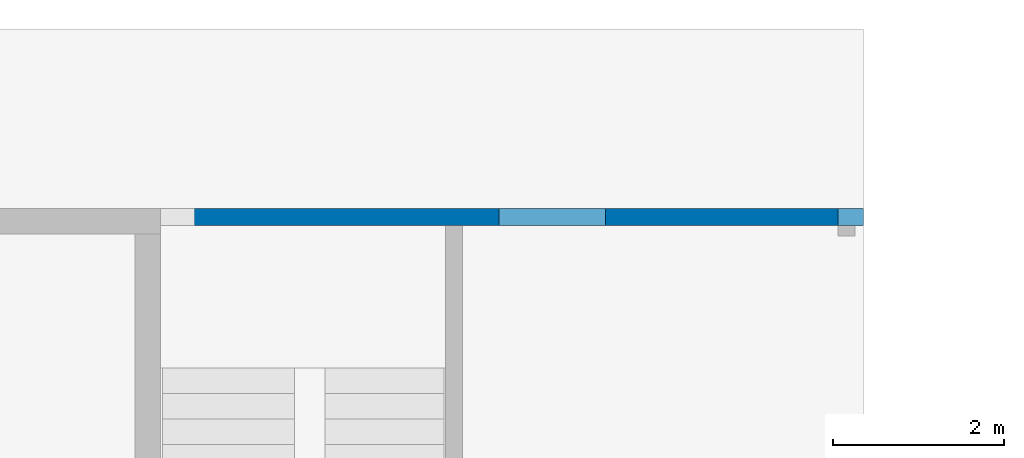
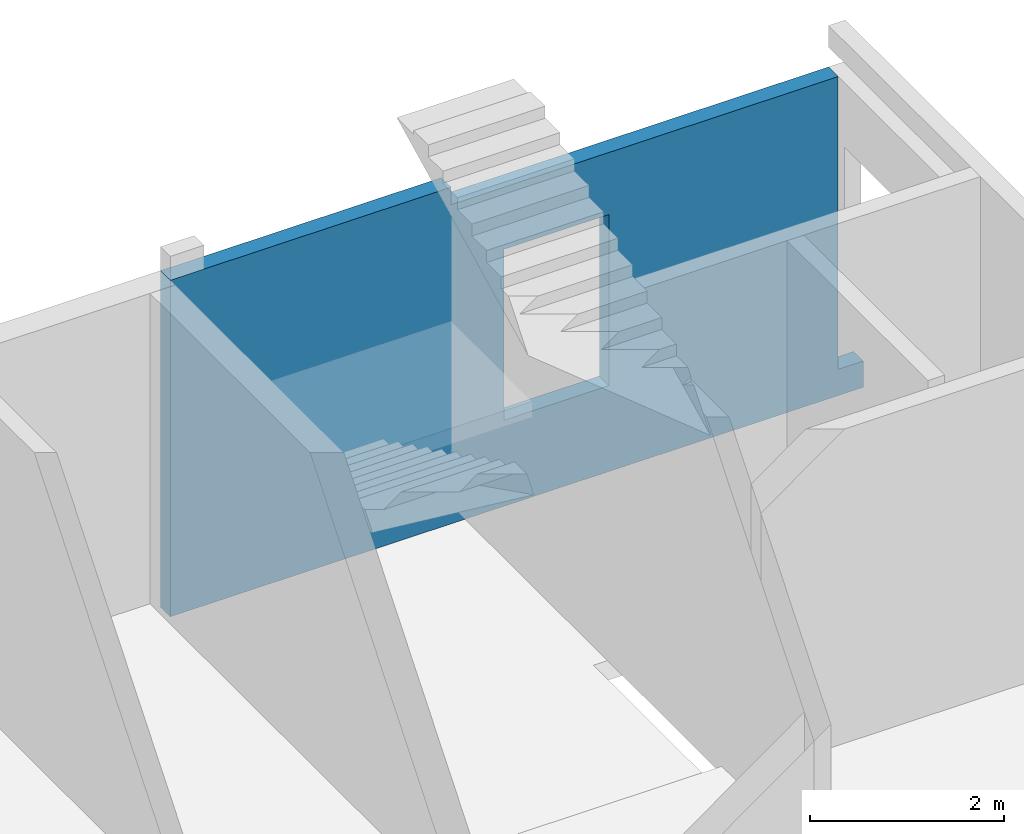
# One storey, part 8 of 8: 1 wall, 13 openings.
"""IFC4 building model written with IfcOpenShell, lengths in millimetres."""

from ifc_helpers import new_model, entity, si_unit, converted_unit, derived_unit, direction, frame, origin, place, context, subcontext, project, spatial, indexed_curve, outline, extrude, polygons, material, type_object, element, save


model = new_model("IFC4")

# Units and contexts
model_context = context("Model", 3, precision=0.01, world=origin(), true_north=direction((6.12303176911189e-17, 1.0)))
plan_context = context("Plan", 3, precision=0.01, world=origin(), true_north=direction((6.12303176911189e-17, 1.0)))
body_context = subcontext(model_context, "Body", "Model", "MODEL_VIEW")
ifc_project = project(units=[si_unit("LENGTHUNIT", "METRE", prefix="MILLI"), si_unit("AREAUNIT", "SQUARE_METRE"), si_unit("VOLUMEUNIT", "CUBIC_METRE"), converted_unit("PLANEANGLEUNIT", "DEGREE", entity("IfcRatioMeasure", 0.0174532925199433), si_unit("PLANEANGLEUNIT", "RADIAN"), dimensions=[0, 0, 0, 0, 0, 0, 0]), si_unit("MASSUNIT", "GRAM", prefix="KILO"), derived_unit("MASSDENSITYUNIT", [(si_unit("MASSUNIT", "GRAM", prefix="KILO"), 1), (si_unit("LENGTHUNIT", "METRE"), -3)]), derived_unit("MOMENTOFINERTIAUNIT", [(si_unit("LENGTHUNIT", "METRE"), 4)]), si_unit("TIMEUNIT", "SECOND"), si_unit("FREQUENCYUNIT", "HERTZ"), si_unit("THERMODYNAMICTEMPERATUREUNIT", "DEGREE_CELSIUS"), derived_unit("THERMALTRANSMITTANCEUNIT", [(si_unit("MASSUNIT", "GRAM", prefix="KILO"), 1), (si_unit("THERMODYNAMICTEMPERATUREUNIT", "KELVIN"), -1), (si_unit("TIMEUNIT", "SECOND"), -3)]), derived_unit("VOLUMETRICFLOWRATEUNIT", [(si_unit("LENGTHUNIT", "METRE"), 3), (si_unit("TIMEUNIT", "SECOND"), -1)]), derived_unit("MASSFLOWRATEUNIT", [(si_unit("MASSUNIT", "GRAM", prefix="KILO"), 1), (si_unit("TIMEUNIT", "SECOND"), -1)]), derived_unit("ROTATIONALFREQUENCYUNIT", [(si_unit("TIMEUNIT", "SECOND"), -1)]), si_unit("ELECTRICCURRENTUNIT", "AMPERE"), si_unit("ELECTRICVOLTAGEUNIT", "VOLT"), si_unit("POWERUNIT", "WATT"), si_unit("FORCEUNIT", "NEWTON", prefix="KILO"), si_unit("ILLUMINANCEUNIT", "LUX"), si_unit("LUMINOUSFLUXUNIT", "LUMEN"), si_unit("LUMINOUSINTENSITYUNIT", "CANDELA"), derived_unit("USERDEFINED", [(si_unit("MASSUNIT", "GRAM", prefix="KILO"), -1), (si_unit("LENGTHUNIT", "METRE"), -2), (si_unit("TIMEUNIT", "SECOND"), 3), (si_unit("LUMINOUSFLUXUNIT", "LUMEN"), 1)]), derived_unit("LINEARVELOCITYUNIT", [(si_unit("LENGTHUNIT", "METRE"), 1), (si_unit("TIMEUNIT", "SECOND"), -1)]), si_unit("PRESSUREUNIT", "PASCAL"), derived_unit("USERDEFINED", [(si_unit("LENGTHUNIT", "METRE"), -2), (si_unit("MASSUNIT", "GRAM", prefix="KILO"), 1), (si_unit("TIMEUNIT", "SECOND"), -2)]), derived_unit("LINEARFORCEUNIT", [(si_unit("MASSUNIT", "GRAM", prefix="KILO"), 1), (si_unit("LENGTHUNIT", "METRE"), 1), (si_unit("TIMEUNIT", "SECOND"), -2), (si_unit("LENGTHUNIT", "METRE"), -1)]), derived_unit("PLANARFORCEUNIT", [(si_unit("MASSUNIT", "GRAM", prefix="KILO"), 1), (si_unit("LENGTHUNIT", "METRE"), 1), (si_unit("TIMEUNIT", "SECOND"), -2), (si_unit("LENGTHUNIT", "METRE"), -2)])], contexts=[model_context, plan_context])

# Site, building, storey
site_placement = place(None, origin())
site = spatial("IfcSite", under=ifc_project, at=site_placement, CompositionType="ELEMENT")
building_placement = place(site_placement, origin())
building = spatial("IfcBuilding", under=site, at=building_placement, CompositionType="ELEMENT")
storey_placement = place(building_placement, origin())
storey = spatial("IfcBuildingStorey", under=building, at=storey_placement, CompositionType="ELEMENT", Elevation=0.0)

# Wall, openings
ifc_material = material()
wall_type = type_object("IfcWallType", PredefinedType="STANDARD")
wall_placement = place(storey_placement, frame((73670.0002685547, 20399.999226356, -480.0), z_axis=(0.0, 0.0, 1.0), x_axis=(-1.0, 0.0, 0.0)))
wall = element("IfcWall", 1, at=wall_placement, inside=storey, type_object=wall_type, material=ifc_material, PredefinedType="NOTDEFINED", context=body_context, shape_type="Tessellation", body=[
    polygons([(-4.19026652712969e-13, -99.9999999999989, 2.70716782324598e-13), (8240.00000000001, -99.9999999999989, 2.70716782324598e-13), (8240.00000000001, -99.9999999999989, 330.0), (8240.00000000001, -99.9999999999989, 4230.0), (7839.99999999997, -99.9999999999989, 4230.0), (4900.0, -99.9999999999946, 4230.0), (4900.0, -99.9999999999946, 4010.0), (300.000000000009, -99.9999999999989, 4010.0), (300.000000000009, -99.9999999999989, 330.0), (100.000000000012, -99.9999999999989, 330.0), (-4.19026652712969e-13, -99.9999999999989, 330.0), (3025.00000000001, -99.9999999999989, 3229.99999999804), (4275.00000000001, -99.9999999999989, 3229.99999999804), (4275.00000000001, -99.9999999999989, 1080.0), (3025.00000000001, -99.9999999999989, 1080.0), (8240.00000000001, 99.9999999999989, 2.70716782324598e-13), (300.0, 99.9999999999989, 2.70716782324598e-13), (-1.09107028414708e-12, 99.9999999999989, 2.70716782324598e-13), (-1.09107028414708e-12, 99.9999999999989, 330.0), (300.000000000009, 99.9999999999989, 330.0), (300.000000000009, 99.9999999999989, 4010.0), (4900.0, 100.000000000003, 4010.0), (4900.0, 100.000000000003, 4230.0), (7839.99999999997, 99.9999999999989, 4230.0), (8240.00000000001, 99.9999999999989, 4230.0), (8240.00000000001, 99.9999999999989, 2550.0), (8240.00000000001, 99.9999999999989, 2350.0), (4275.00000000001, 99.9999999999989, 3229.99999999804), (3025.00000000001, 99.9999999999989, 3229.99999999804), (3025.00000000001, 99.9999999999989, 1080.0), (4275.00000000001, 99.9999999999989, 1080.0)], [[[1, 2, 3, 4, 5, 6, 7, 8, 9, 10, 11], [12, 13, 14, 15]], [[16, 17, 18, 19, 20, 21, 22, 23, 24, 25, 26, 27], [28, 29, 30, 31]], [[2, 1, 18, 17, 16]], [[4, 3, 2, 16, 27, 26, 25]], [[4, 25, 24, 23, 6, 5]], [[20, 19, 11, 10, 9]], [[18, 1, 11, 19]], [[20, 9, 8, 21]], [[7, 22, 21, 8]], [[22, 7, 6, 23]], [[12, 29, 28, 13]], [[13, 28, 31, 14]], [[14, 31, 30, 15]], [[29, 12, 15, 30]]], closed=True),
])
opening_1_placement = place(wall_placement, origin())
element("IfcOpeningElement", 2, at=opening_1_placement, cuts=wall, PredefinedType="OPENING", context=body_context, shape_type="SweptSolid", body=[
    extrude(outline(indexed_curve([(-850.000000000002, -849.999999999994), (850.0, -849.999999999994), (850.0, 849.999999999994), (-850.000000000002, 849.999999999994), (-850.000000000002, -849.999999999994)], self_intersect=False)), frame((54250.0, -100.0, 2180.0), z_axis=(0.0, 1.0, 0.0), x_axis=(1.0, 0.0, 0.0)), (0.0, 0.0, 1.0), 200.000000000959),
])
opening_2_placement = place(wall_placement, origin())
element("IfcOpeningElement", 3, at=opening_2_placement, cuts=wall, PredefinedType="OPENING", context=body_context, shape_type="SweptSolid", body=[
    extrude(outline(indexed_curve([(-850.000000000002, -849.999999999994), (849.999999999997, -849.999999999994), (849.999999999997, 849.999999999994), (-850.000000000002, 849.999999999994), (-850.000000000002, -849.999999999994)], self_intersect=False)), frame((50950.0, -100.0, 2180.0), z_axis=(0.0, 1.0, 0.0), x_axis=(1.0, 0.0, 0.0)), (0.0, 0.0, 1.0), 200.000000000959),
])
opening_3_placement = place(wall_placement, origin())
element("IfcOpeningElement", 4, at=opening_3_placement, cuts=wall, PredefinedType="OPENING", context=body_context, shape_type="SweptSolid", body=[
    extrude(outline(indexed_curve([(-850.000000000002, -849.999999999994), (849.999999999997, -849.999999999994), (849.999999999997, 849.999999999994), (-850.000000000002, 849.999999999994), (-850.000000000002, -849.999999999994)], self_intersect=False)), frame((47650.0, -100.0, 2180.0), z_axis=(0.0, 1.0, 0.0), x_axis=(1.0, 0.0, 0.0)), (0.0, 0.0, 1.0), 200.000000000959),
])
opening_4_placement = place(wall_placement, origin())
element("IfcOpeningElement", 5, at=opening_4_placement, cuts=wall, PredefinedType="OPENING", context=body_context, shape_type="SweptSolid", body=[
    extrude(outline(indexed_curve([(-850.000000000002, -849.999999999994), (849.999999999997, -849.999999999994), (849.999999999997, 849.999999999994), (-850.000000000002, 849.999999999994), (-850.000000000002, -849.999999999994)], self_intersect=False)), frame((44350.0, -100.0, 2180.0), z_axis=(0.0, 1.0, 0.0), x_axis=(1.0, 0.0, 0.0)), (0.0, 0.0, 1.0), 200.000000000959),
])
opening_5_placement = place(wall_placement, origin())
element("IfcOpeningElement", 6, at=opening_5_placement, cuts=wall, PredefinedType="OPENING", context=body_context, shape_type="SweptSolid", body=[
    extrude(outline(indexed_curve([(-849.999999999997, -849.999999999994), (850.000000000002, -849.999999999994), (850.000000000002, 849.999999999994), (-849.999999999997, 849.999999999994), (-849.999999999997, -849.999999999994)], self_intersect=False)), frame((41050.0, -100.0, 2180.0), z_axis=(0.0, 1.0, 0.0), x_axis=(1.0, 0.0, 0.0)), (0.0, 0.0, 1.0), 200.000000000959),
])
opening_6_placement = place(wall_placement, origin())
element("IfcOpeningElement", 7, at=opening_6_placement, cuts=wall, PredefinedType="OPENING", context=body_context, shape_type="SweptSolid", body=[
    extrude(outline(indexed_curve([(-849.999999999997, -849.999999999994), (850.000000000006, -849.999999999994), (850.000000000006, 849.999999999994), (-849.999999999997, 849.999999999994), (-849.999999999997, -849.999999999994)], self_intersect=False)), frame((34250.0, -100.0, 2180.0), z_axis=(0.0, 1.0, 0.0), x_axis=(1.0, 0.0, 0.0)), (0.0, 0.0, 1.0), 200.000000000959),
])
opening_7_placement = place(wall_placement, origin())
element("IfcOpeningElement", 8, at=opening_7_placement, cuts=wall, PredefinedType="OPENING", context=body_context, shape_type="SweptSolid", body=[
    extrude(outline(indexed_curve([(-850.000000000006, -849.999999999994), (849.999999999997, -849.999999999994), (849.999999999997, 849.999999999994), (-850.000000000006, 849.999999999994), (-850.000000000006, -849.999999999994)], self_intersect=False)), frame((30750.0, -100.0, 2180.0), z_axis=(0.0, 1.0, 0.0), x_axis=(1.0, 0.0, 0.0)), (0.0, 0.0, 1.0), 200.000000000959),
])
opening_8_placement = place(wall_placement, origin())
element("IfcOpeningElement", 9, at=opening_8_placement, cuts=wall, PredefinedType="OPENING", context=body_context, shape_type="SweptSolid", body=[
    extrude(outline(indexed_curve([(-849.999999999997, -849.999999999994), (850.000000000006, -849.999999999994), (850.000000000006, 849.999999999994), (-849.999999999997, 849.999999999994), (-849.999999999997, -849.999999999994)], self_intersect=False)), frame((27450.0, -100.0, 2180.0), z_axis=(0.0, 1.0, 0.0), x_axis=(1.0, 0.0, 0.0)), (0.0, 0.0, 1.0), 200.000000000959),
])
opening_9_placement = place(wall_placement, origin())
element("IfcOpeningElement", 10, at=opening_9_placement, cuts=wall, PredefinedType="OPENING", context=body_context, shape_type="SweptSolid", body=[
    extrude(outline(indexed_curve([(-849.999999999997, -849.999999999994), (850.000000000006, -849.999999999994), (850.000000000006, 849.999999999994), (-849.999999999997, 849.999999999994), (-849.999999999997, -849.999999999994)], self_intersect=False)), frame((24150.0, -100.0, 2180.0), z_axis=(0.0, 1.0, 0.0), x_axis=(1.0, 0.0, 0.0)), (0.0, 0.0, 1.0), 200.000000000959),
])
opening_10_placement = place(wall_placement, origin())
element("IfcOpeningElement", 11, at=opening_10_placement, cuts=wall, PredefinedType="OPENING", context=body_context, shape_type="SweptSolid", body=[
    extrude(outline(indexed_curve([(-849.999999999997, -849.999999999994), (850.000000000002, -849.999999999994), (850.000000000002, 849.999999999994), (-849.999999999997, 849.999999999994), (-849.999999999997, -849.999999999994)], self_intersect=False)), frame((37750.0, -100.0, 2180.0), z_axis=(0.0, 1.0, 0.0), x_axis=(1.0, 0.0, 0.0)), (0.0, 0.0, 1.0), 200.000000000959),
])
opening_11_placement = place(wall_placement, origin())
element("IfcOpeningElement", 12, at=opening_11_placement, cuts=wall, PredefinedType="OPENING", context=body_context, shape_type="SweptSolid", body=[
    extrude(outline(indexed_curve([(-1349.99999999902, -2100.0), (1349.99999999902, -2100.0), (1349.99999999902, 2100.0), (-1349.99999999902, 2100.0), (-1349.99999999902, -2100.0)], self_intersect=False)), frame((60270.0, -200.0, 1680.0), z_axis=(0.0, 1.0, 0.0), x_axis=(0.0, 0.0, -1.0)), (0.0, 0.0, 1.0), 400.000000001945),
])
opening_12_placement = place(wall_placement, origin())
element("IfcOpeningElement", 13, at=opening_12_placement, cuts=wall, PredefinedType="OPENING", context=body_context, shape_type="SweptSolid", body=[
    extrude(outline(indexed_curve([(-849.999999999997, -849.999999999994), (850.000000000006, -849.999999999994), (850.000000000006, 849.999999999994), (-849.999999999997, 849.999999999994), (-849.999999999997, -849.999999999994)], self_intersect=False)), frame((20850.0, -100.0, 2180.0), z_axis=(0.0, 1.0, 0.0), x_axis=(1.0, 0.0, 0.0)), (0.0, 0.0, 1.0), 200.000000000959),
])
opening_13_placement = place(wall_placement, frame((73670.0002685547, 20399.999226356, 480.0), z_axis=(0.0, 0.0, 1.0), x_axis=(-1.0, 0.0, 0.0)))
element("IfcOpeningElement", 14, at=opening_13_placement, cuts=wall, PredefinedType="OPENING", context=body_context, shape_type="SweptSolid", body=[
    extrude(outline(indexed_curve([(-624.999999999996, -1074.99999999902), (625.000000000005, -1074.99999999902), (625.000000000005, 1074.99999999902), (-624.999999999996, 1074.99999999902), (-624.999999999996, -1074.99999999902)], self_intersect=False)), frame((70020.0002685547, 20599.9992263579, 1675.0), z_axis=(0.0, -1.0, 0.0), x_axis=(-1.0, 0.0, 0.0)), (0.0, 0.0, 1.0), 400.000000001945),
])

save(model, "model.ifc")
